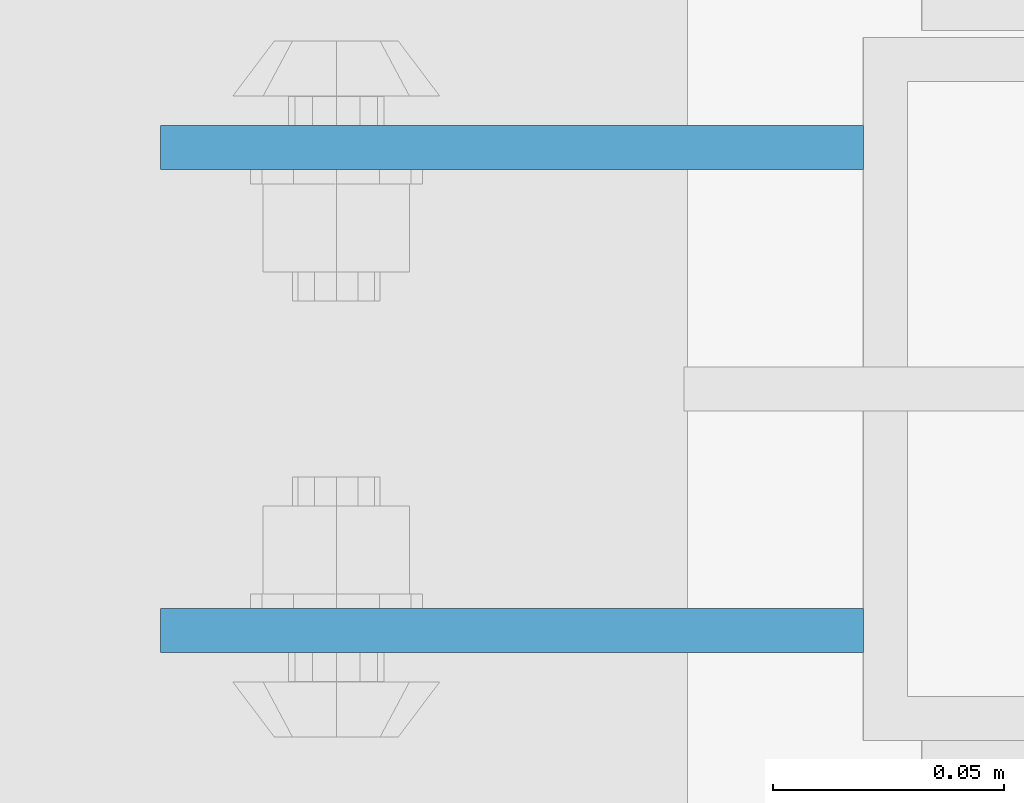
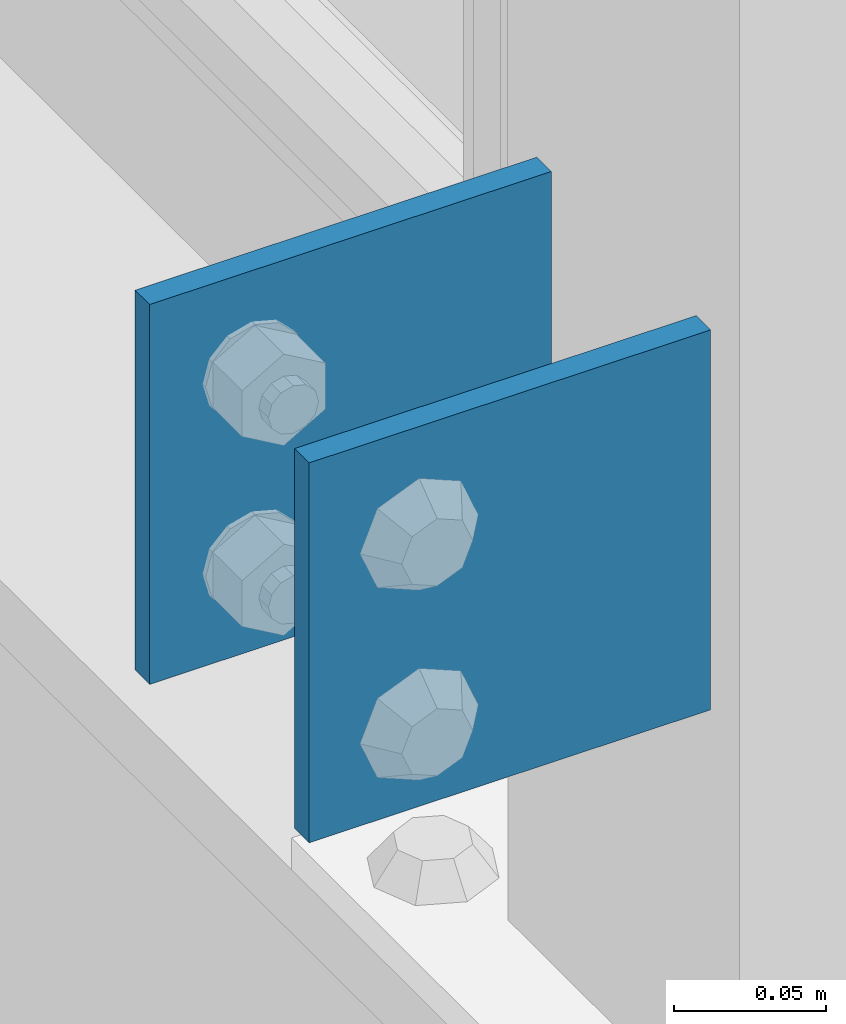
# One storey, part 1309 of 1876: 2 beams, 1 element without a shape of its own.
"""IFC2X3 building model written with IfcOpenShell, lengths in millimetres."""

import ifcopenshell
import ifcopenshell.guid

model = None  # the IFC model being written
_history = None  # IfcOwnerHistory: only IFC2X3 demands one
_inside = {}  # id of a spatial element -> (the spatial element, [elements in it])
_under = {}  # id of a project, library or spatial element -> (it, [spatial elements below it])
_declared = {}  # id of a project -> (the project, [libraries it declares])
_typed = {}  # id of a type object -> (the type object, [elements of that type])
_made_of = {}  # id of a material, layer set ... -> (it, [elements and type objects made of it])


def new_model(schema):
    """Start an empty IFC model of exactly this schema.

    Asked for "IFC4X3", IfcOpenShell would pick the latest addendum, in which some entities
    have other attributes; the version numbers below select the first issue.
    IFC2X3 requires an IfcOwnerHistory on every rooted entity: one is made here for all.
    """
    global model, _history
    if schema == "IFC4X3":
        model = ifcopenshell.file(schema_version=(4, 3, 0, 0))
    else:
        model = ifcopenshell.file(schema=schema)
    _inside.clear()
    _under.clear()
    _declared.clear()
    _typed.clear()
    _made_of.clear()
    _history = None
    if model.schema == "IFC2X3":
        org = make("IfcOrganization", Name="unknown")
        user = make(
            "IfcPersonAndOrganization",
            ThePerson=make("IfcPerson", FamilyName="unknown"),
            TheOrganization=org,
        )
        app = make(
            "IfcApplication",
            ApplicationDeveloper=org,
            Version="unknown",
            ApplicationFullName="unknown",
            ApplicationIdentifier="unknown",
        )
        _history = make(
            "IfcOwnerHistory",
            OwningUser=user,
            OwningApplication=app,
            ChangeAction="ADDED",
            CreationDate=0,
        )
    return model


def make(cls, **values):
    """One entity of the class cls with the attributes given. An attribute that is None is left unset."""
    return model.create_entity(
        cls, **{name: value for name, value in values.items() if value is not None}
    )


def rooted(cls, **values):
    """An entity with a GlobalId (a new one), such as an element, a storey or a relation."""
    return make(cls, GlobalId=ifcopenshell.guid.new(), OwnerHistory=_history, **values)


def si_unit(unit_type, name, prefix=None):
    """IfcSIUnit, for example si_unit("LENGTHUNIT", "METRE", prefix="MILLI")."""
    return make("IfcSIUnit", UnitType=unit_type, Prefix=prefix, Name=name)


def assignment(units):
    """IfcUnitAssignment: the units of a project."""
    return None if units is None else make("IfcUnitAssignment", Units=units)


def point(xyz):
    """IfcCartesianPoint."""
    return None if xyz is None else make("IfcCartesianPoint", Coordinates=xyz)


def direction(xyz):
    """IfcDirection."""
    return None if xyz is None else make("IfcDirection", DirectionRatios=xyz)


def frame(location, z_axis=None, x_axis=None):
    """IfcAxis2Placement3D, a coordinate frame: its origin and axes. An axis left out is left unset."""
    return make(
        "IfcAxis2Placement3D",
        Location=point(location),
        Axis=direction(z_axis),
        RefDirection=direction(x_axis),
    )


def origin_with_axes():
    """The frame at (0, 0, 0) with the z axis (0, 0, 1) and the x axis (1, 0, 0) written out."""
    return frame((0.0, 0.0, 0.0), z_axis=(0.0, 0.0, 1.0), x_axis=(1.0, 0.0, 0.0))


def place(relative_to, where):
    """IfcLocalPlacement: puts the frame where relative to a parent placement (None: the world)."""
    return make(
        "IfcLocalPlacement", PlacementRelTo=relative_to, RelativePlacement=where
    )


def context(
    kind, dimensions, precision=None, world=None, true_north=None, identifier=None
):
    """IfcGeometricRepresentationContext, for example the 3D "Model" context."""
    return make(
        "IfcGeometricRepresentationContext",
        ContextIdentifier=identifier,
        ContextType=kind,
        CoordinateSpaceDimension=dimensions,
        Precision=precision,
        WorldCoordinateSystem=world,
        TrueNorth=true_north,
    )


def subcontext(parent, identifier, kind, view, scale=None):
    """IfcGeometricRepresentationSubContext, for example "Body" below "Model"."""
    return make(
        "IfcGeometricRepresentationSubContext",
        ContextIdentifier=identifier,
        ContextType=kind,
        ParentContext=parent,
        TargetScale=scale,
        TargetView=view,
    )


def project(units=None, contexts=None):
    """IfcProject with its units and contexts."""
    return rooted(
        "IfcProject",
        Name="project",
        RepresentationContexts=contexts,
        UnitsInContext=assignment(units),
    )


def spatial(cls, under=None, at=None, **own):
    """A site, building, storey or space (cls), placed at a placement, below another one or the project."""
    s = rooted(cls, ObjectPlacement=at, **own)
    if under is not None:
        _under.setdefault(under.id(), (under, []))[1].append(s)
    return s


def faces_of(points, faces, orient=None, outer=None):
    """IfcFace entities. A face is a list of loops; a loop is a list of indices into points, from 0.

    orient and outer hold one flag for each loop. By default every Orientation is true, the
    first loop of a face is its IfcFaceOuterBound and the others are IfcFaceBound.
    """
    made = []
    for i, loops in enumerate(faces):
        bounds = []
        for j, loop in enumerate(loops):
            is_outer = j == 0 if outer is None else outer[i][j]
            bounds.append(
                make(
                    "IfcFaceOuterBound" if is_outer else "IfcFaceBound",
                    Bound=make("IfcPolyLoop", Polygon=[points[k] for k in loop]),
                    Orientation=True if orient is None else orient[i][j],
                )
            )
        made.append(make("IfcFace", Bounds=bounds))
    return made


def faceted_brep(points, faces, orient=None, outer=None, voids=None):
    """IfcFacetedBrep: a solid bounded by flat faces; with voids (closed shells), ...WithVoids."""
    shared = [point(p) for p in points]
    hull = make("IfcClosedShell", CfsFaces=faces_of(shared, faces, orient, outer))
    if voids is None:
        return make("IfcFacetedBrep", Outer=hull)
    return make(
        "IfcFacetedBrepWithVoids",
        Outer=hull,
        Voids=[
            make(cls, CfsFaces=faces_of(shared, fs, o, b)) for cls, fs, o, b in voids
        ],
    )


def shape(context_of_items, identifier, shape_type, items):
    """IfcShapeRepresentation: the items that make up one representation, for example the "Body"."""
    return make(
        "IfcShapeRepresentation",
        ContextOfItems=context_of_items,
        RepresentationIdentifier=identifier,
        RepresentationType=shape_type,
        Items=items,
    )


def material(Name=None, Category=None):
    """IfcMaterial."""
    return make("IfcMaterial", Name=Name, Category=Category)


def made_of(thing, what):
    """Note that an element or type object is made of a material, layer set ...; save() writes the relation."""
    if what is not None:
        _made_of.setdefault(what.id(), (what, []))[1].append(thing)
    return thing


def type_object(cls, material=None, **own):
    """A type object (cls), such as IfcWallType, which elements share."""
    return made_of(rooted(cls, **own), material)


def element(
    cls,
    number,
    at=None,
    inside=None,
    cuts=None,
    type_object=None,
    material=None,
    context=None,
    identifier="Body",
    shape_type=None,
    held_by="IfcProductDefinitionShape",
    body=None,
    shapes=None,
    **own,
):
    """One element of the class cls, such as IfcWall. Its Tag is "e" and its number.

    at: its placement. inside: the storey or other place that contains it. cuts: it is an
    opening in that element (IfcRelVoidsElement). A single representation is given by context,
    identifier, shape_type and body (its items); several are given by shapes. held_by: the class
    of the entity that holds the representations. save() writes the other relations.
    """
    e = rooted(cls, Tag="e%d" % number, ObjectPlacement=at, **own)
    if body is not None:
        shapes = [shape(context, identifier, shape_type, body)]
    if shapes is not None:
        e.Representation = make(held_by, Representations=shapes)
    if inside is not None:
        _inside.setdefault(inside.id(), (inside, []))[1].append(e)
    if cuts is not None:
        rooted(
            "IfcRelVoidsElement", RelatingBuildingElement=cuts, RelatedOpeningElement=e
        )
    if type_object is not None:
        _typed.setdefault(type_object.id(), (type_object, []))[1].append(e)
    return made_of(e, material)


def aggregate(whole, parts):
    """IfcRelAggregates: a whole, such as a stair, and the parts it consists of."""
    return rooted("IfcRelAggregates", RelatingObject=whole, RelatedObjects=parts)


def save(model, path):
    """Write the relations noted so far, then the file.

    IfcRelAggregates (storeys below a building ...), IfcRelContainedInSpatialStructure (elements
    in a storey), IfcRelDefinesByType, IfcRelAssociatesMaterial and IfcRelDeclares: one each for
    every whole, place, type object, material and project.
    """
    for whole, parts in _under.values():
        aggregate(whole, parts)
    for where, things in _inside.values():
        rooted(
            "IfcRelContainedInSpatialStructure",
            RelatedElements=things,
            RelatingStructure=where,
        )
    for kind, things in _typed.values():
        rooted("IfcRelDefinesByType", RelatedObjects=things, RelatingType=kind)
    for what, things in _made_of.values():
        rooted("IfcRelAssociatesMaterial", RelatedObjects=things, RelatingMaterial=what)
    for by, libraries in _declared.values():
        rooted("IfcRelDeclares", RelatingContext=by, RelatedDefinitions=libraries)
    model.write(path)


model = new_model("IFC2X3")

# Units and contexts
model_context = context("Model", 3, precision=1e-05, world=origin_with_axes())
body_context = subcontext(model_context, "Body", "Model", "MODEL_VIEW")
ifc_project = project(units=[si_unit("LENGTHUNIT", "METRE", prefix="MILLI"), si_unit("AREAUNIT", "SQUARE_METRE"), si_unit("VOLUMEUNIT", "CUBIC_METRE"), si_unit("MASSUNIT", "GRAM", prefix="KILO"), si_unit("TIMEUNIT", "SECOND"), si_unit("PLANEANGLEUNIT", "RADIAN"), si_unit("SOLIDANGLEUNIT", "STERADIAN"), si_unit("THERMODYNAMICTEMPERATUREUNIT", "DEGREE_CELSIUS"), si_unit("LUMINOUSINTENSITYUNIT", "LUMEN")], contexts=[model_context])

# Site, building, storey
site_placement = place(None, origin_with_axes())
site = spatial("IfcSite", under=ifc_project, at=site_placement, CompositionType="ELEMENT")
building_placement = place(site_placement, origin_with_axes())
building = spatial("IfcBuilding", under=site, at=building_placement, Name="Undefined", CompositionType="ELEMENT")
storey_placement = place(building_placement, origin_with_axes())
storey = spatial("IfcBuildingStorey", under=building, at=storey_placement, Name="Undefined", CompositionType="ELEMENT", Elevation=0.0)

# Assembly, beams
assembly_placement = place(storey_placement, origin_with_axes())
assembly = element("IfcElementAssembly", 1, at=assembly_placement, inside=storey, Name="BEAM", AssemblyPlace="NOTDEFINED", PredefinedType="RIGID_FRAME")
ifc_material = material(Name="STEEL/A36")
beam_type = type_object("IfcBeamType", PredefinedType="NOTDEFINED")
beam_1_placement = place(assembly_placement, frame((-76.2, 11736.3875, 5384.8), z_axis=(0.0, 0.0, -1.0), x_axis=(-1.0, 0.0, 0.0)))
beam_1 = element("IfcBeam", 2, at=beam_1_placement, type_object=beam_type, material=ifc_material, Name="PLATE", context=body_context, shape_type="Brep", body=[
    faceted_brep([(0.0, 4.76249999999982, -76.1999999999998), (3.63797880709171e-12, 4.76249999999982, 76.1999969482422), (152.399993896484, 4.76250000000073, 76.1999969482422), (152.4, 4.76249999999982, -76.1999999999998), (3.63797880709171e-12, -4.76249999999982, 76.1999969482422), (152.399993896484, -4.76250000000073, 76.1999969482422), (0.0, -4.76249999999982, -76.1999999999998), (152.4, -4.76249999999982, -76.1999999999998)], [[[0, 1, 2, 3]], [[4, 5, 2, 1]], [[4, 6, 7, 5]], [[6, 0, 3, 7]], [[5, 7, 3, 2]], [[6, 4, 1, 0]]]),
])
beam_2_placement = place(assembly_placement, frame((-76.2, 11631.6125, 5384.8), z_axis=(0.0, 0.0, -1.0), x_axis=(-1.0, 0.0, 0.0)))
beam_2 = element("IfcBeam", 3, at=beam_2_placement, type_object=beam_type, material=ifc_material, Name="PLATE", context=body_context, shape_type="Brep", body=[
    faceted_brep([(0.0, 4.76249999999982, -76.1999999999998), (3.63797880709171e-12, 4.76249999999982, 76.1999969482422), (152.399993896484, 4.76250000000073, 76.1999969482422), (152.4, 4.76249999999982, -76.1999999999998), (3.63797880709171e-12, -4.76249999999982, 76.1999969482422), (152.399993896484, -4.76250000000073, 76.1999969482422), (0.0, -4.76249999999982, -76.1999999999998), (152.4, -4.76249999999982, -76.1999999999998)], [[[0, 1, 2, 3]], [[4, 5, 2, 1]], [[4, 6, 7, 5]], [[6, 0, 3, 7]], [[5, 7, 3, 2]], [[6, 4, 1, 0]]]),
])
aggregate(assembly, [beam_1, beam_2])

save(model, "model.ifc")
